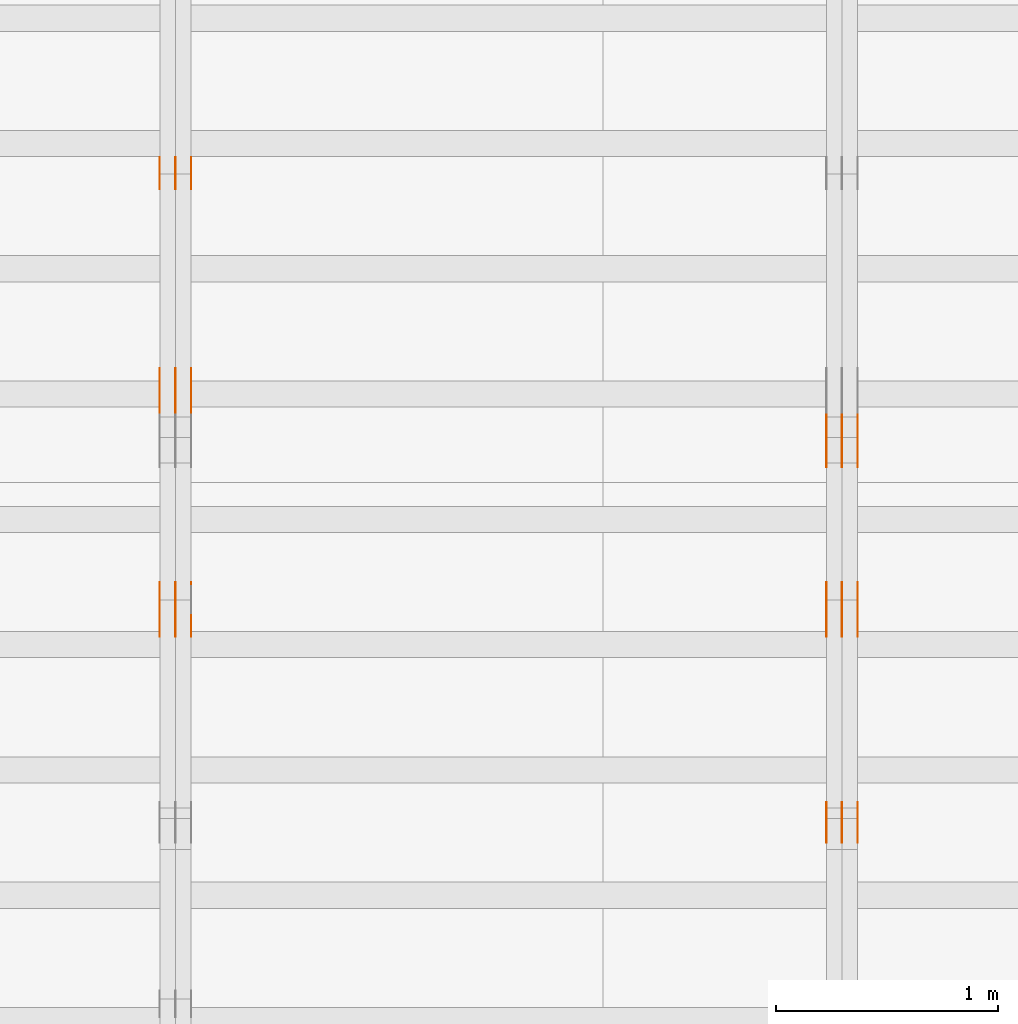
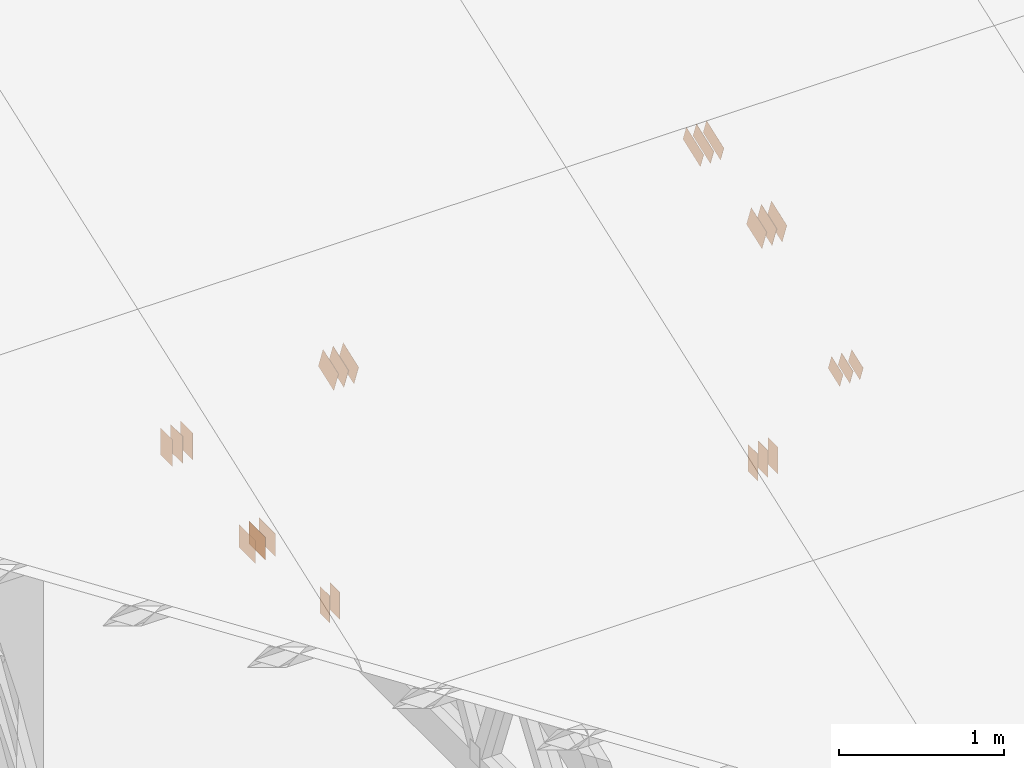
# One storey, part 93 of 189: 31 proxies.
"""IFC2X3 building model written with IfcOpenShell, lengths in millimetres."""

from ifc_helpers import new_model, entity, si_unit, converted_unit, derived_unit, direction, frame, frame_2d, origin, origin_2d_with_axis, place, context, subcontext, project, spatial, polyline, rectangle, outline, extrude, source, transform, mapped, material, type_object, type_shapes, element, save


model = new_model("IFC2X3")

# Units and contexts
model_context = context("Model", 3, precision=0.01, world=origin(), true_north=direction((6.12303176911189e-17, 1.0)))
body_context = subcontext(model_context, "Body", "Model", "MODEL_VIEW")
ifc_project = project(units=[si_unit("LENGTHUNIT", "METRE", prefix="MILLI"), si_unit("AREAUNIT", "SQUARE_METRE"), si_unit("VOLUMEUNIT", "CUBIC_METRE"), converted_unit("PLANEANGLEUNIT", "DEGREE", entity("IfcRatioMeasure", 0.0174532925199433), si_unit("PLANEANGLEUNIT", "RADIAN"), dimensions=[0, 0, 0, 0, 0, 0, 0]), si_unit("MASSUNIT", "GRAM", prefix="KILO"), derived_unit("MASSDENSITYUNIT", [(si_unit("MASSUNIT", "GRAM", prefix="KILO"), 1), (si_unit("LENGTHUNIT", "METRE"), -3)]), si_unit("TIMEUNIT", "SECOND"), si_unit("FREQUENCYUNIT", "HERTZ"), si_unit("THERMODYNAMICTEMPERATUREUNIT", "DEGREE_CELSIUS"), derived_unit("THERMALTRANSMITTANCEUNIT", [(si_unit("MASSUNIT", "GRAM", prefix="KILO"), 1), (si_unit("THERMODYNAMICTEMPERATUREUNIT", "KELVIN"), -1), (si_unit("TIMEUNIT", "SECOND"), -3)]), derived_unit("VOLUMETRICFLOWRATEUNIT", [(si_unit("LENGTHUNIT", "METRE"), 3), (si_unit("TIMEUNIT", "SECOND"), -1)]), si_unit("ELECTRICCURRENTUNIT", "AMPERE"), si_unit("ELECTRICVOLTAGEUNIT", "VOLT"), si_unit("POWERUNIT", "WATT"), si_unit("FORCEUNIT", "NEWTON"), si_unit("ILLUMINANCEUNIT", "LUX"), si_unit("LUMINOUSFLUXUNIT", "LUMEN"), si_unit("LUMINOUSINTENSITYUNIT", "CANDELA"), derived_unit("USERDEFINED", [(si_unit("MASSUNIT", "GRAM", prefix="KILO"), -1), (si_unit("LENGTHUNIT", "METRE"), -2), (si_unit("TIMEUNIT", "SECOND"), 3), (si_unit("LUMINOUSFLUXUNIT", "LUMEN"), 1)]), derived_unit("LINEARVELOCITYUNIT", [(si_unit("LENGTHUNIT", "METRE"), 1), (si_unit("TIMEUNIT", "SECOND"), -1)]), si_unit("PRESSUREUNIT", "PASCAL"), derived_unit("USERDEFINED", [(si_unit("LENGTHUNIT", "METRE"), -2), (si_unit("MASSUNIT", "GRAM", prefix="KILO"), 1), (si_unit("TIMEUNIT", "SECOND"), -2)])], contexts=[model_context])

# Site, building, storey
site_placement = place(None, origin())
site = spatial("IfcSite", under=ifc_project, at=site_placement, CompositionType="ELEMENT")
building_placement = place(site_placement, origin())
building = spatial("IfcBuilding", under=site, at=building_placement, CompositionType="ELEMENT")
storey_placement = place(building_placement, origin())
storey = spatial("IfcBuildingStorey", under=building, at=storey_placement, Name="Default", CompositionType="ELEMENT", Elevation=0.0)

# Proxies
ifc_material_1 = material(Name="IfcSurfaceStyle #169866")
building_element_proxy_type_1 = type_object("IfcBuildingElementProxyType", PredefinedType="NOTDEFINED", material=ifc_material_1)
shared_shape_1 = source(origin(), body_context, "Body", "SweptSolid", [
    extrude(outline(polyline([(-112.500654374667, -59.9999021691247), (112.500117969231, -59.9999021691247), (112.500612624162, 59.9999021691247), (-112.500076218726, 59.9999021691247), (-112.500654374667, -59.9999021691247)])), frame((112.500612624162, 60.0003514046321, 0.0), z_axis=(0.0, 0.0, 1.0), x_axis=(-1.0, 0.0, 0.0)), (0.0, 0.0, 1.0), 1.3),
])
type_shapes(building_element_proxy_type_1, [shared_shape_1])
proxy_1_placement = place(building_placement, frame((30301.3, 5418.0703125, 2162.37353515625), z_axis=(-1.0, 0.0, 0.0), x_axis=(0.0, 0.939692620785908, 0.342020143325669)))
element("IfcBuildingElementProxy", 1, at=proxy_1_placement, inside=storey, type_object=building_element_proxy_type_1, material=ifc_material_1, context=body_context, shape_type="MappedRepresentation", body=[
    mapped(shared_shape_1, transform((0.0, 0.0, 0.0), scale=1.0)),
])
ifc_material_2 = material(Name="IfcSurfaceStyle #169809")
building_element_proxy_type_2 = type_object("IfcBuildingElementProxyType", PredefinedType="NOTDEFINED", material=ifc_material_2)
shared_shape_2 = source(origin(), body_context, "Body", "SweptSolid", [
    extrude(outline(polyline([(-112.500654374667, -59.9999021691247), (112.500117969231, -59.9999021691247), (112.500612624162, 59.9999021691247), (-112.500076218726, 59.9999021691247), (-112.500654374667, -59.9999021691247)])), frame((112.500612624162, 60.0003514046321, 0.0), z_axis=(0.0, 0.0, 1.0), x_axis=(-1.0, 0.0, 0.0)), (0.0, 0.0, 1.0), 1.29999999999998),
])
type_shapes(building_element_proxy_type_2, [shared_shape_2])
proxy_2_placement = place(building_placement, frame((30230.0, 5418.0703125, 2162.37353515625), z_axis=(-1.0, 0.0, 0.0), x_axis=(0.0, 0.939692620785908, 0.342020143325669)))
element("IfcBuildingElementProxy", 2, at=proxy_2_placement, inside=storey, type_object=building_element_proxy_type_2, material=ifc_material_2, context=body_context, shape_type="MappedRepresentation", body=[
    mapped(shared_shape_2, transform((0.0, 0.0, 0.0), scale=1.0)),
])
ifc_material_3 = material(Name="IfcSurfaceStyle #169752")
building_element_proxy_type_3 = type_object("IfcBuildingElementProxyType", PredefinedType="NOTDEFINED", material=ifc_material_3)
shared_shape_3 = source(origin(), body_context, "Body", "SweptSolid", [
    extrude(outline(polyline([(-112.500654374667, -59.9999021691247), (112.500117969231, -59.9999021691247), (112.500612624162, 59.9999021691247), (-112.500076218726, 59.9999021691247), (-112.500654374667, -59.9999021691247)])), frame((112.500612624162, 60.0003514046321, 0.0), z_axis=(0.0, 0.0, 1.0), x_axis=(-1.0, 0.0, 0.0)), (0.0, 0.0, 1.0), 1.29999999999998),
])
type_shapes(building_element_proxy_type_3, [shared_shape_3])
proxy_3_placement = place(building_placement, frame((30231.3, 5418.0703125, 2162.37353515625), z_axis=(-1.0, 0.0, 0.0), x_axis=(0.0, 0.939692620785908, 0.342020143325669)))
element("IfcBuildingElementProxy", 3, at=proxy_3_placement, inside=storey, type_object=building_element_proxy_type_3, material=ifc_material_3, context=body_context, shape_type="MappedRepresentation", body=[
    mapped(shared_shape_3, transform((0.0, 0.0, 0.0), scale=1.0)),
])
ifc_material_4 = material(Name="IfcSurfaceStyle #169695")
building_element_proxy_type_4 = type_object("IfcBuildingElementProxyType", PredefinedType="NOTDEFINED", material=ifc_material_4)
shared_shape_4 = source(origin(), body_context, "Body", "SweptSolid", [
    extrude(outline(polyline([(-112.500654374667, -59.9999021691247), (112.500117969231, -59.9999021691247), (112.500612624162, 59.9999021691247), (-112.500076218726, 59.9999021691247), (-112.500654374667, -59.9999021691247)])), frame((112.500612624162, 60.0003514046321, 0.0), z_axis=(0.0, 0.0, 1.0), x_axis=(-1.0, 0.0, 0.0)), (0.0, 0.0, 1.0), 1.29999999999999),
])
type_shapes(building_element_proxy_type_4, [shared_shape_4])
proxy_4_placement = place(building_placement, frame((30160.0, 5418.0703125, 2162.37353515625), z_axis=(-1.0, 0.0, 0.0), x_axis=(0.0, 0.939692620785908, 0.342020143325669)))
element("IfcBuildingElementProxy", 4, at=proxy_4_placement, inside=storey, type_object=building_element_proxy_type_4, material=ifc_material_4, context=body_context, shape_type="MappedRepresentation", body=[
    mapped(shared_shape_4, transform((0.0, 0.0, 0.0), scale=1.0)),
])
ifc_material_5 = material(Name="IfcSurfaceStyle #169182")
building_element_proxy_type_5 = type_object("IfcBuildingElementProxyType", PredefinedType="NOTDEFINED", material=ifc_material_5)
shared_shape_5 = source(origin(), body_context, "Body", "SweptSolid", [
    extrude(rectangle(XDim=200.0, YDim=120.0, at=origin_2d_with_axis()), frame((100.0, 60.0, 0.0), z_axis=(0.0, 0.0, 1.0), x_axis=(-1.0, 0.0, 0.0)), (0.0, 0.0, 1.0), 1.3),
])
type_shapes(building_element_proxy_type_5, [shared_shape_5])
proxy_5_placement = place(building_placement, frame((30301.3, 4760.65625, 145.0), z_axis=(-1.0, 0.0, 0.0), x_axis=(0.0, 0.0, 1.0)))
element("IfcBuildingElementProxy", 5, at=proxy_5_placement, inside=storey, type_object=building_element_proxy_type_5, material=ifc_material_5, context=body_context, shape_type="MappedRepresentation", body=[
    mapped(shared_shape_5, transform((0.0, 0.0, 0.0), scale=1.0)),
])
ifc_material_6 = material(Name="IfcSurfaceStyle #169125")
building_element_proxy_type_6 = type_object("IfcBuildingElementProxyType", PredefinedType="NOTDEFINED", material=ifc_material_6)
shared_shape_6 = source(origin(), body_context, "Body", "SweptSolid", [
    extrude(rectangle(XDim=200.0, YDim=120.0, at=origin_2d_with_axis()), frame((100.0, 60.0, 0.0), z_axis=(0.0, 0.0, 1.0), x_axis=(-1.0, 0.0, 0.0)), (0.0, 0.0, 1.0), 1.29999999999998),
])
type_shapes(building_element_proxy_type_6, [shared_shape_6])
proxy_6_placement = place(building_placement, frame((30230.0, 4760.65625, 145.0), z_axis=(-1.0, 0.0, 0.0), x_axis=(0.0, 0.0, 1.0)))
element("IfcBuildingElementProxy", 6, at=proxy_6_placement, inside=storey, type_object=building_element_proxy_type_6, material=ifc_material_6, context=body_context, shape_type="MappedRepresentation", body=[
    mapped(shared_shape_6, transform((0.0, 0.0, 0.0), scale=1.0)),
])
ifc_material_7 = material(Name="IfcSurfaceStyle #169068")
building_element_proxy_type_7 = type_object("IfcBuildingElementProxyType", PredefinedType="NOTDEFINED", material=ifc_material_7)
shared_shape_7 = source(origin(), body_context, "Body", "SweptSolid", [
    extrude(rectangle(XDim=200.0, YDim=120.0, at=origin_2d_with_axis()), frame((100.0, 60.0, 0.0), z_axis=(0.0, 0.0, 1.0), x_axis=(-1.0, 0.0, 0.0)), (0.0, 0.0, 1.0), 1.29999999999998),
])
type_shapes(building_element_proxy_type_7, [shared_shape_7])
proxy_7_placement = place(building_placement, frame((30231.3, 4760.65625, 145.0), z_axis=(-1.0, 0.0, 0.0), x_axis=(0.0, 0.0, 1.0)))
element("IfcBuildingElementProxy", 7, at=proxy_7_placement, inside=storey, type_object=building_element_proxy_type_7, material=ifc_material_7, context=body_context, shape_type="MappedRepresentation", body=[
    mapped(shared_shape_7, transform((0.0, 0.0, 0.0), scale=1.0)),
])
ifc_material_8 = material(Name="IfcSurfaceStyle #169011")
building_element_proxy_type_8 = type_object("IfcBuildingElementProxyType", PredefinedType="NOTDEFINED", material=ifc_material_8)
shared_shape_8 = source(origin(), body_context, "Body", "SweptSolid", [
    extrude(rectangle(XDim=200.0, YDim=120.0, at=origin_2d_with_axis()), frame((100.0, 60.0, 0.0), z_axis=(0.0, 0.0, 1.0), x_axis=(-1.0, 0.0, 0.0)), (0.0, 0.0, 1.0), 1.29999999999999),
])
type_shapes(building_element_proxy_type_8, [shared_shape_8])
proxy_8_placement = place(building_placement, frame((30160.0, 4760.65625, 145.0), z_axis=(-1.0, 0.0, 0.0), x_axis=(0.0, 0.0, 1.0)))
element("IfcBuildingElementProxy", 8, at=proxy_8_placement, inside=storey, type_object=building_element_proxy_type_8, material=ifc_material_8, context=body_context, shape_type="MappedRepresentation", body=[
    mapped(shared_shape_8, transform((0.0, 0.0, 0.0), scale=1.0)),
])
ifc_material_9 = material(Name="IfcSurfaceStyle #168954")
building_element_proxy_type_9 = type_object("IfcBuildingElementProxyType", PredefinedType="NOTDEFINED", material=ifc_material_9)
shared_shape_9 = source(origin(), body_context, "Body", "SweptSolid", [
    extrude(outline(polyline([(-74.9994515581384, -59.9999039432178), (74.9998536965286, -59.9999039432178), (75.0003483514593, 59.9999039432178), (-75.0007504898495, 59.9999039432178), (-74.9994515581384, -59.9999039432178)])), frame((75.0003483514593, 60.0003496305408, 0.0), z_axis=(0.0, 0.0, 1.0), x_axis=(-1.0, 0.0, 0.0)), (0.0, 0.0, 1.0), 1.3),
])
type_shapes(building_element_proxy_type_9, [shared_shape_9])
proxy_9_placement = place(building_placement, frame((30301.3, 3726.8984375, 1559.607421875), z_axis=(-1.0, 0.0, 0.0), x_axis=(0.0, 0.939692620785908, 0.342020143325669)))
element("IfcBuildingElementProxy", 9, at=proxy_9_placement, inside=storey, type_object=building_element_proxy_type_9, material=ifc_material_9, context=body_context, shape_type="MappedRepresentation", body=[
    mapped(shared_shape_9, transform((0.0, 0.0, 0.0), scale=1.0)),
])
ifc_material_10 = material(Name="IfcSurfaceStyle #168897")
building_element_proxy_type_10 = type_object("IfcBuildingElementProxyType", PredefinedType="NOTDEFINED", material=ifc_material_10)
shared_shape_10 = source(origin(), body_context, "Body", "SweptSolid", [
    extrude(outline(polyline([(-74.9994515581384, -59.9999039432178), (74.9998536965286, -59.9999039432178), (75.0003483514593, 59.9999039432178), (-75.0007504898495, 59.9999039432178), (-74.9994515581384, -59.9999039432178)])), frame((75.0003483514593, 60.0003496305408, 0.0), z_axis=(0.0, 0.0, 1.0), x_axis=(-1.0, 0.0, 0.0)), (0.0, 0.0, 1.0), 1.29999999999999),
])
type_shapes(building_element_proxy_type_10, [shared_shape_10])
proxy_10_placement = place(building_placement, frame((30230.0, 3726.8984375, 1559.607421875), z_axis=(-1.0, 0.0, 0.0), x_axis=(0.0, 0.939692620785908, 0.342020143325669)))
element("IfcBuildingElementProxy", 10, at=proxy_10_placement, inside=storey, type_object=building_element_proxy_type_10, material=ifc_material_10, context=body_context, shape_type="MappedRepresentation", body=[
    mapped(shared_shape_10, transform((0.0, 0.0, 0.0), scale=1.0)),
])
ifc_material_11 = material(Name="IfcSurfaceStyle #168840")
building_element_proxy_type_11 = type_object("IfcBuildingElementProxyType", PredefinedType="NOTDEFINED", material=ifc_material_11)
shared_shape_11 = source(origin(), body_context, "Body", "SweptSolid", [
    extrude(outline(polyline([(-74.9994515581384, -59.9999039432178), (74.9998536965286, -59.9999039432178), (75.0003483514593, 59.9999039432178), (-75.0007504898495, 59.9999039432178), (-74.9994515581384, -59.9999039432178)])), frame((75.0003483514593, 60.0003496305408, 0.0), z_axis=(0.0, 0.0, 1.0), x_axis=(-1.0, 0.0, 0.0)), (0.0, 0.0, 1.0), 1.29999999999999),
])
type_shapes(building_element_proxy_type_11, [shared_shape_11])
proxy_11_placement = place(building_placement, frame((30231.3, 3726.8984375, 1559.607421875), z_axis=(-1.0, 0.0, 0.0), x_axis=(0.0, 0.939692620785908, 0.342020143325669)))
element("IfcBuildingElementProxy", 11, at=proxy_11_placement, inside=storey, type_object=building_element_proxy_type_11, material=ifc_material_11, context=body_context, shape_type="MappedRepresentation", body=[
    mapped(shared_shape_11, transform((0.0, 0.0, 0.0), scale=1.0)),
])
ifc_material_12 = material(Name="IfcSurfaceStyle #168783")
building_element_proxy_type_12 = type_object("IfcBuildingElementProxyType", PredefinedType="NOTDEFINED", material=ifc_material_12)
shared_shape_12 = source(origin(), body_context, "Body", "SweptSolid", [
    extrude(outline(polyline([(-74.9994515581384, -59.9999039432178), (74.9998536965286, -59.9999039432178), (75.0003483514593, 59.9999039432178), (-75.0007504898495, 59.9999039432178), (-74.9994515581384, -59.9999039432178)])), frame((75.0003483514593, 60.0003496305408, 0.0), z_axis=(0.0, 0.0, 1.0), x_axis=(-1.0, 0.0, 0.0)), (0.0, 0.0, 1.0), 1.29999999999999),
])
type_shapes(building_element_proxy_type_12, [shared_shape_12])
proxy_12_placement = place(building_placement, frame((30160.0, 3726.8984375, 1559.607421875), z_axis=(-1.0, 0.0, 0.0), x_axis=(0.0, 0.939692620785908, 0.342020143325669)))
element("IfcBuildingElementProxy", 12, at=proxy_12_placement, inside=storey, type_object=building_element_proxy_type_12, material=ifc_material_12, context=body_context, shape_type="MappedRepresentation", body=[
    mapped(shared_shape_12, transform((0.0, 0.0, 0.0), scale=1.0)),
])
ifc_material_13 = material(Name="IfcSurfaceStyle #164286")
building_element_proxy_type_13 = type_object("IfcBuildingElementProxyType", PredefinedType="NOTDEFINED", material=ifc_material_13)
shared_shape_13 = source(origin(), body_context, "Body", "SweptSolid", [
    extrude(outline(polyline([(-99.9993269270171, -84.0000832532405), (99.9997189122032, -84.0000832532405), (99.9992851765118, 84.0000832532405), (-99.999677161698, 84.0000832532405), (-99.9993269270171, -84.0000832532405)])), frame((99.9999283659736, 84.0000832532405, 0.0), z_axis=(0.0, 0.0, 1.0), x_axis=(-1.0, 0.0, 0.0)), (0.0, 0.0, 1.0), 1.3),
])
type_shapes(building_element_proxy_type_13, [shared_shape_13])
proxy_13_placement = place(building_placement, frame((30301.3, 4654.06379965055, 2052.96988554922), z_axis=(-1.0, 0.0, 0.0), x_axis=(0.0, 0.939692620785908, 0.342020143325669)))
element("IfcBuildingElementProxy", 13, at=proxy_13_placement, inside=storey, type_object=building_element_proxy_type_13, material=ifc_material_13, context=body_context, shape_type="MappedRepresentation", body=[
    mapped(shared_shape_13, transform((0.0, 0.0, 0.0), scale=1.0)),
])
ifc_material_14 = material(Name="IfcSurfaceStyle #164229")
building_element_proxy_type_14 = type_object("IfcBuildingElementProxyType", PredefinedType="NOTDEFINED", material=ifc_material_14)
shared_shape_14 = source(origin(), body_context, "Body", "SweptSolid", [
    extrude(outline(polyline([(-99.9993269270171, -84.0000832532405), (99.9997189122032, -84.0000832532405), (99.9992851765118, 84.0000832532405), (-99.999677161698, 84.0000832532405), (-99.9993269270171, -84.0000832532405)])), frame((99.9999283659736, 84.0000832532405, 0.0), z_axis=(0.0, 0.0, 1.0), x_axis=(-1.0, 0.0, 0.0)), (0.0, 0.0, 1.0), 1.29999999999998),
])
type_shapes(building_element_proxy_type_14, [shared_shape_14])
proxy_14_placement = place(building_placement, frame((30230.0, 4654.06379965055, 2052.96988554922), z_axis=(-1.0, 0.0, 0.0), x_axis=(0.0, 0.939692620785908, 0.342020143325669)))
element("IfcBuildingElementProxy", 14, at=proxy_14_placement, inside=storey, type_object=building_element_proxy_type_14, material=ifc_material_14, context=body_context, shape_type="MappedRepresentation", body=[
    mapped(shared_shape_14, transform((0.0, 0.0, 0.0), scale=1.0)),
])
ifc_material_15 = material(Name="IfcSurfaceStyle #164172")
building_element_proxy_type_15 = type_object("IfcBuildingElementProxyType", PredefinedType="NOTDEFINED", material=ifc_material_15)
shared_shape_15 = source(origin(), body_context, "Body", "SweptSolid", [
    extrude(outline(polyline([(-99.9993269270171, -84.0000832532405), (99.9997189122032, -84.0000832532405), (99.9992851765118, 84.0000832532405), (-99.999677161698, 84.0000832532405), (-99.9993269270171, -84.0000832532405)])), frame((99.9999283659736, 84.0000832532405, 0.0), z_axis=(0.0, 0.0, 1.0), x_axis=(-1.0, 0.0, 0.0)), (0.0, 0.0, 1.0), 1.29999999999998),
])
type_shapes(building_element_proxy_type_15, [shared_shape_15])
proxy_15_placement = place(building_placement, frame((30231.3, 4654.06379965055, 2052.96988554922), z_axis=(-1.0, 0.0, 0.0), x_axis=(0.0, 0.939692620785908, 0.342020143325669)))
element("IfcBuildingElementProxy", 15, at=proxy_15_placement, inside=storey, type_object=building_element_proxy_type_15, material=ifc_material_15, context=body_context, shape_type="MappedRepresentation", body=[
    mapped(shared_shape_15, transform((0.0, 0.0, 0.0), scale=1.0)),
])
ifc_material_16 = material(Name="IfcSurfaceStyle #164115")
building_element_proxy_type_16 = type_object("IfcBuildingElementProxyType", PredefinedType="NOTDEFINED", material=ifc_material_16)
shared_shape_16 = source(origin(), body_context, "Body", "SweptSolid", [
    extrude(outline(polyline([(-99.9993269270171, -84.0000832532405), (99.9997189122032, -84.0000832532405), (99.9992851765118, 84.0000832532405), (-99.999677161698, 84.0000832532405), (-99.9993269270171, -84.0000832532405)])), frame((99.9999283659736, 84.0000832532405, 0.0), z_axis=(0.0, 0.0, 1.0), x_axis=(-1.0, 0.0, 0.0)), (0.0, 0.0, 1.0), 1.29999999999999),
])
type_shapes(building_element_proxy_type_16, [shared_shape_16])
proxy_16_placement = place(building_placement, frame((30160.0, 4654.06379965055, 2052.96988554922), z_axis=(-1.0, 0.0, 0.0), x_axis=(0.0, 0.939692620785908, 0.342020143325669)))
element("IfcBuildingElementProxy", 16, at=proxy_16_placement, inside=storey, type_object=building_element_proxy_type_16, material=ifc_material_16, context=body_context, shape_type="MappedRepresentation", body=[
    mapped(shared_shape_16, transform((0.0, 0.0, 0.0), scale=1.0)),
])
ifc_material_17 = material(Name="IfcSurfaceStyle #157952")
building_element_proxy_type_17 = type_object("IfcBuildingElementProxyType", PredefinedType="NOTDEFINED", material=ifc_material_17)
shared_shape_17 = source(origin(), body_context, "Body", "SweptSolid", [
    extrude(rectangle(XDim=200.0, YDim=144.0, at=frame_2d((1.4210854715202e-14, 0.0), x_axis=(1.0, 0.0))), frame((100.0, 72.0, 0.0), z_axis=(0.0, 0.0, 1.0), x_axis=(-1.0, 0.0, 0.0)), (0.0, 0.0, 1.0), 1.3),
])
type_shapes(building_element_proxy_type_17, [shared_shape_17])
proxy_17_placement = place(building_placement, frame((27301.3, 6668.833984375, 145.0), z_axis=(-1.0, 0.0, 0.0), x_axis=(0.0, 0.0, 1.0)))
element("IfcBuildingElementProxy", 17, at=proxy_17_placement, inside=storey, type_object=building_element_proxy_type_17, material=ifc_material_17, context=body_context, shape_type="MappedRepresentation", body=[
    mapped(shared_shape_17, transform((0.0, 0.0, 0.0), scale=1.0)),
])
ifc_material_18 = material(Name="IfcSurfaceStyle #157895")
building_element_proxy_type_18 = type_object("IfcBuildingElementProxyType", PredefinedType="NOTDEFINED", material=ifc_material_18)
shared_shape_18 = source(origin(), body_context, "Body", "SweptSolid", [
    extrude(rectangle(XDim=200.0, YDim=144.0, at=frame_2d((1.4210854715202e-14, 0.0), x_axis=(1.0, 0.0))), frame((100.0, 72.0, 0.0), z_axis=(0.0, 0.0, 1.0), x_axis=(-1.0, 0.0, 0.0)), (0.0, 0.0, 1.0), 1.29999999999998),
])
type_shapes(building_element_proxy_type_18, [shared_shape_18])
proxy_18_placement = place(building_placement, frame((27230.0, 6668.833984375, 145.0), z_axis=(-1.0, 0.0, 0.0), x_axis=(0.0, 0.0, 1.0)))
element("IfcBuildingElementProxy", 18, at=proxy_18_placement, inside=storey, type_object=building_element_proxy_type_18, material=ifc_material_18, context=body_context, shape_type="MappedRepresentation", body=[
    mapped(shared_shape_18, transform((0.0, 0.0, 0.0), scale=1.0)),
])
ifc_material_19 = material(Name="IfcSurfaceStyle #157838")
building_element_proxy_type_19 = type_object("IfcBuildingElementProxyType", PredefinedType="NOTDEFINED", material=ifc_material_19)
shared_shape_19 = source(origin(), body_context, "Body", "SweptSolid", [
    extrude(rectangle(XDim=200.0, YDim=144.0, at=frame_2d((1.4210854715202e-14, 0.0), x_axis=(1.0, 0.0))), frame((100.0, 72.0, 0.0), z_axis=(0.0, 0.0, 1.0), x_axis=(-1.0, 0.0, 0.0)), (0.0, 0.0, 1.0), 1.29999999999998),
])
type_shapes(building_element_proxy_type_19, [shared_shape_19])
proxy_19_placement = place(building_placement, frame((27231.3, 6668.833984375, 145.0), z_axis=(-1.0, 0.0, 0.0), x_axis=(0.0, 0.0, 1.0)))
element("IfcBuildingElementProxy", 19, at=proxy_19_placement, inside=storey, type_object=building_element_proxy_type_19, material=ifc_material_19, context=body_context, shape_type="MappedRepresentation", body=[
    mapped(shared_shape_19, transform((0.0, 0.0, 0.0), scale=1.0)),
])
ifc_material_20 = material(Name="IfcSurfaceStyle #157781")
building_element_proxy_type_20 = type_object("IfcBuildingElementProxyType", PredefinedType="NOTDEFINED", material=ifc_material_20)
shared_shape_20 = source(origin(), body_context, "Body", "SweptSolid", [
    extrude(rectangle(XDim=200.0, YDim=144.0, at=frame_2d((1.4210854715202e-14, 0.0), x_axis=(1.0, 0.0))), frame((100.0, 72.0, 0.0), z_axis=(0.0, 0.0, 1.0), x_axis=(-1.0, 0.0, 0.0)), (0.0, 0.0, 1.0), 1.29999999999999),
])
type_shapes(building_element_proxy_type_20, [shared_shape_20])
proxy_20_placement = place(building_placement, frame((27160.0, 6668.833984375, 145.0), z_axis=(-1.0, 0.0, 0.0), x_axis=(0.0, 0.0, 1.0)))
element("IfcBuildingElementProxy", 20, at=proxy_20_placement, inside=storey, type_object=building_element_proxy_type_20, material=ifc_material_20, context=body_context, shape_type="MappedRepresentation", body=[
    mapped(shared_shape_20, transform((0.0, 0.0, 0.0), scale=1.0)),
])
ifc_material_21 = material(Name="IfcSurfaceStyle #157724")
building_element_proxy_type_21 = type_object("IfcBuildingElementProxyType", PredefinedType="NOTDEFINED", material=ifc_material_21)
shared_shape_21 = source(origin(), body_context, "Body", "SweptSolid", [
    extrude(rectangle(XDim=200.0, YDim=168.0, at=origin_2d_with_axis()), frame((100.0, 84.0, 0.0), z_axis=(0.0, 0.0, 1.0), x_axis=(-1.0, 0.0, 0.0)), (0.0, 0.0, 1.0), 1.3),
])
type_shapes(building_element_proxy_type_21, [shared_shape_21])
proxy_21_placement = place(building_placement, frame((27301.3, 5662.466796875, 206.5), z_axis=(-1.0, 0.0, 0.0), x_axis=(0.0, 1.0, 0.0)))
element("IfcBuildingElementProxy", 21, at=proxy_21_placement, inside=storey, type_object=building_element_proxy_type_21, material=ifc_material_21, context=body_context, shape_type="MappedRepresentation", body=[
    mapped(shared_shape_21, transform((0.0, 0.0, 0.0), scale=1.0)),
])
ifc_material_22 = material(Name="IfcSurfaceStyle #157667")
building_element_proxy_type_22 = type_object("IfcBuildingElementProxyType", PredefinedType="NOTDEFINED", material=ifc_material_22)
shared_shape_22 = source(origin(), body_context, "Body", "SweptSolid", [
    extrude(rectangle(XDim=200.0, YDim=168.0, at=origin_2d_with_axis()), frame((100.0, 84.0, 0.0), z_axis=(0.0, 0.0, 1.0), x_axis=(-1.0, 0.0, 0.0)), (0.0, 0.0, 1.0), 1.29999999999998),
])
type_shapes(building_element_proxy_type_22, [shared_shape_22])
proxy_22_placement = place(building_placement, frame((27230.0, 5662.466796875, 206.5), z_axis=(-1.0, 0.0, 0.0), x_axis=(0.0, 1.0, 0.0)))
element("IfcBuildingElementProxy", 22, at=proxy_22_placement, inside=storey, type_object=building_element_proxy_type_22, material=ifc_material_22, context=body_context, shape_type="MappedRepresentation", body=[
    mapped(shared_shape_22, transform((0.0, 0.0, 0.0), scale=1.0)),
])
ifc_material_23 = material(Name="IfcSurfaceStyle #157610")
building_element_proxy_type_23 = type_object("IfcBuildingElementProxyType", PredefinedType="NOTDEFINED", material=ifc_material_23)
shared_shape_23 = source(origin(), body_context, "Body", "SweptSolid", [
    extrude(rectangle(XDim=200.0, YDim=168.0, at=origin_2d_with_axis()), frame((100.0, 84.0, 0.0), z_axis=(0.0, 0.0, 1.0), x_axis=(-1.0, 0.0, 0.0)), (0.0, 0.0, 1.0), 1.29999999999998),
])
type_shapes(building_element_proxy_type_23, [shared_shape_23])
proxy_23_placement = place(building_placement, frame((27231.3, 5662.466796875, 206.5), z_axis=(-1.0, 0.0, 0.0), x_axis=(0.0, 1.0, 0.0)))
element("IfcBuildingElementProxy", 23, at=proxy_23_placement, inside=storey, type_object=building_element_proxy_type_23, material=ifc_material_23, context=body_context, shape_type="MappedRepresentation", body=[
    mapped(shared_shape_23, transform((0.0, 0.0, 0.0), scale=1.0)),
])
ifc_material_24 = material(Name="IfcSurfaceStyle #157553")
building_element_proxy_type_24 = type_object("IfcBuildingElementProxyType", PredefinedType="NOTDEFINED", material=ifc_material_24)
shared_shape_24 = source(origin(), body_context, "Body", "SweptSolid", [
    extrude(rectangle(XDim=200.0, YDim=168.0, at=origin_2d_with_axis()), frame((100.0, 84.0, 0.0), z_axis=(0.0, 0.0, 1.0), x_axis=(-1.0, 0.0, 0.0)), (0.0, 0.0, 1.0), 1.29999999999999),
])
type_shapes(building_element_proxy_type_24, [shared_shape_24])
proxy_24_placement = place(building_placement, frame((27160.0, 5662.466796875, 206.5), z_axis=(-1.0, 0.0, 0.0), x_axis=(0.0, 1.0, 0.0)))
element("IfcBuildingElementProxy", 24, at=proxy_24_placement, inside=storey, type_object=building_element_proxy_type_24, material=ifc_material_24, context=body_context, shape_type="MappedRepresentation", body=[
    mapped(shared_shape_24, transform((0.0, 0.0, 0.0), scale=1.0)),
])
ifc_material_25 = material(Name="IfcSurfaceStyle #153335")
building_element_proxy_type_25 = type_object("IfcBuildingElementProxyType", PredefinedType="NOTDEFINED", material=ifc_material_25)
shared_shape_25 = source(origin(), body_context, "Body", "SweptSolid", [
    extrude(rectangle(XDim=200.0, YDim=120.0, at=origin_2d_with_axis()), frame((100.0, 60.0, 0.0), z_axis=(0.0, 0.0, 1.0), x_axis=(-1.0, 0.0, 0.0)), (0.0, 0.0, 1.0), 1.29999999999998),
])
type_shapes(building_element_proxy_type_25, [shared_shape_25])
proxy_25_placement = place(building_placement, frame((27230.0, 4760.65625, 145.0), z_axis=(-1.0, 0.0, 0.0), x_axis=(0.0, 0.0, 1.0)))
element("IfcBuildingElementProxy", 25, at=proxy_25_placement, inside=storey, type_object=building_element_proxy_type_25, material=ifc_material_25, context=body_context, shape_type="MappedRepresentation", body=[
    mapped(shared_shape_25, transform((0.0, 0.0, 0.0), scale=1.0)),
])
ifc_material_26 = material(Name="IfcSurfaceStyle #153278")
building_element_proxy_type_26 = type_object("IfcBuildingElementProxyType", PredefinedType="NOTDEFINED", material=ifc_material_26)
shared_shape_26 = source(origin(), body_context, "Body", "SweptSolid", [
    extrude(rectangle(XDim=200.0, YDim=120.0, at=origin_2d_with_axis()), frame((100.0, 60.0, 0.0), z_axis=(0.0, 0.0, 1.0), x_axis=(-1.0, 0.0, 0.0)), (0.0, 0.0, 1.0), 1.29999999999998),
])
type_shapes(building_element_proxy_type_26, [shared_shape_26])
proxy_26_placement = place(building_placement, frame((27231.3, 4760.65625, 145.0), z_axis=(-1.0, 0.0, 0.0), x_axis=(0.0, 0.0, 1.0)))
element("IfcBuildingElementProxy", 26, at=proxy_26_placement, inside=storey, type_object=building_element_proxy_type_26, material=ifc_material_26, context=body_context, shape_type="MappedRepresentation", body=[
    mapped(shared_shape_26, transform((0.0, 0.0, 0.0), scale=1.0)),
])
ifc_material_27 = material(Name="IfcSurfaceStyle #153221")
building_element_proxy_type_27 = type_object("IfcBuildingElementProxyType", PredefinedType="NOTDEFINED", material=ifc_material_27)
shared_shape_27 = source(origin(), body_context, "Body", "SweptSolid", [
    extrude(rectangle(XDim=200.0, YDim=120.0, at=origin_2d_with_axis()), frame((100.0, 60.0, 0.0), z_axis=(0.0, 0.0, 1.0), x_axis=(-1.0, 0.0, 0.0)), (0.0, 0.0, 1.0), 1.29999999999999),
])
type_shapes(building_element_proxy_type_27, [shared_shape_27])
proxy_27_placement = place(building_placement, frame((27160.0, 4760.65625, 145.0), z_axis=(-1.0, 0.0, 0.0), x_axis=(0.0, 0.0, 1.0)))
element("IfcBuildingElementProxy", 27, at=proxy_27_placement, inside=storey, type_object=building_element_proxy_type_27, material=ifc_material_27, context=body_context, shape_type="MappedRepresentation", body=[
    mapped(shared_shape_27, transform((0.0, 0.0, 0.0), scale=1.0)),
])
ifc_material_28 = material(Name="IfcSurfaceStyle #148496")
building_element_proxy_type_28 = type_object("IfcBuildingElementProxyType", PredefinedType="NOTDEFINED", material=ifc_material_28)
shared_shape_28 = source(origin(), body_context, "Body", "SweptSolid", [
    extrude(outline(polyline([(-99.9993269270171, -84.0000832532405), (99.9997189122032, -84.0000832532405), (99.9992851765118, 84.0000832532405), (-99.999677161698, 84.0000832532405), (-99.9993269270171, -84.0000832532405)])), frame((99.9999283659736, 84.0000832532405, 0.0), z_axis=(0.0, 0.0, 1.0), x_axis=(-1.0, 0.0, 0.0)), (0.0, 0.0, 1.0), 1.3),
])
type_shapes(building_element_proxy_type_28, [shared_shape_28])
proxy_28_placement = place(building_placement, frame((27301.3, 4654.06379965055, 2052.96988554922), z_axis=(-1.0, 0.0, 0.0), x_axis=(0.0, 0.939692620785908, 0.342020143325669)))
element("IfcBuildingElementProxy", 28, at=proxy_28_placement, inside=storey, type_object=building_element_proxy_type_28, material=ifc_material_28, context=body_context, shape_type="MappedRepresentation", body=[
    mapped(shared_shape_28, transform((0.0, 0.0, 0.0), scale=1.0)),
])
ifc_material_29 = material(Name="IfcSurfaceStyle #148439")
building_element_proxy_type_29 = type_object("IfcBuildingElementProxyType", PredefinedType="NOTDEFINED", material=ifc_material_29)
shared_shape_29 = source(origin(), body_context, "Body", "SweptSolid", [
    extrude(outline(polyline([(-99.9993269270171, -84.0000832532405), (99.9997189122032, -84.0000832532405), (99.9992851765118, 84.0000832532405), (-99.999677161698, 84.0000832532405), (-99.9993269270171, -84.0000832532405)])), frame((99.9999283659736, 84.0000832532405, 0.0), z_axis=(0.0, 0.0, 1.0), x_axis=(-1.0, 0.0, 0.0)), (0.0, 0.0, 1.0), 1.29999999999998),
])
type_shapes(building_element_proxy_type_29, [shared_shape_29])
proxy_29_placement = place(building_placement, frame((27230.0, 4654.06379965055, 2052.96988554922), z_axis=(-1.0, 0.0, 0.0), x_axis=(0.0, 0.939692620785908, 0.342020143325669)))
element("IfcBuildingElementProxy", 29, at=proxy_29_placement, inside=storey, type_object=building_element_proxy_type_29, material=ifc_material_29, context=body_context, shape_type="MappedRepresentation", body=[
    mapped(shared_shape_29, transform((0.0, 0.0, 0.0), scale=1.0)),
])
ifc_material_30 = material(Name="IfcSurfaceStyle #148382")
building_element_proxy_type_30 = type_object("IfcBuildingElementProxyType", PredefinedType="NOTDEFINED", material=ifc_material_30)
shared_shape_30 = source(origin(), body_context, "Body", "SweptSolid", [
    extrude(outline(polyline([(-99.9993269270171, -84.0000832532405), (99.9997189122032, -84.0000832532405), (99.9992851765118, 84.0000832532405), (-99.999677161698, 84.0000832532405), (-99.9993269270171, -84.0000832532405)])), frame((99.9999283659736, 84.0000832532405, 0.0), z_axis=(0.0, 0.0, 1.0), x_axis=(-1.0, 0.0, 0.0)), (0.0, 0.0, 1.0), 1.29999999999998),
])
type_shapes(building_element_proxy_type_30, [shared_shape_30])
proxy_30_placement = place(building_placement, frame((27231.3, 4654.06379965055, 2052.96988554922), z_axis=(-1.0, 0.0, 0.0), x_axis=(0.0, 0.939692620785908, 0.342020143325669)))
element("IfcBuildingElementProxy", 30, at=proxy_30_placement, inside=storey, type_object=building_element_proxy_type_30, material=ifc_material_30, context=body_context, shape_type="MappedRepresentation", body=[
    mapped(shared_shape_30, transform((0.0, 0.0, 0.0), scale=1.0)),
])
ifc_material_31 = material(Name="IfcSurfaceStyle #148325")
building_element_proxy_type_31 = type_object("IfcBuildingElementProxyType", PredefinedType="NOTDEFINED", material=ifc_material_31)
shared_shape_31 = source(origin(), body_context, "Body", "SweptSolid", [
    extrude(outline(polyline([(-99.9993269270171, -84.0000832532405), (99.9997189122032, -84.0000832532405), (99.9992851765118, 84.0000832532405), (-99.999677161698, 84.0000832532405), (-99.9993269270171, -84.0000832532405)])), frame((99.9999283659736, 84.0000832532405, 0.0), z_axis=(0.0, 0.0, 1.0), x_axis=(-1.0, 0.0, 0.0)), (0.0, 0.0, 1.0), 1.29999999999999),
])
type_shapes(building_element_proxy_type_31, [shared_shape_31])
proxy_31_placement = place(building_placement, frame((27160.0, 4654.06379965055, 2052.96988554922), z_axis=(-1.0, 0.0, 0.0), x_axis=(0.0, 0.939692620785908, 0.342020143325669)))
element("IfcBuildingElementProxy", 31, at=proxy_31_placement, inside=storey, type_object=building_element_proxy_type_31, material=ifc_material_31, context=body_context, shape_type="MappedRepresentation", body=[
    mapped(shared_shape_31, transform((0.0, 0.0, 0.0), scale=1.0)),
])

save(model, "model.ifc")
